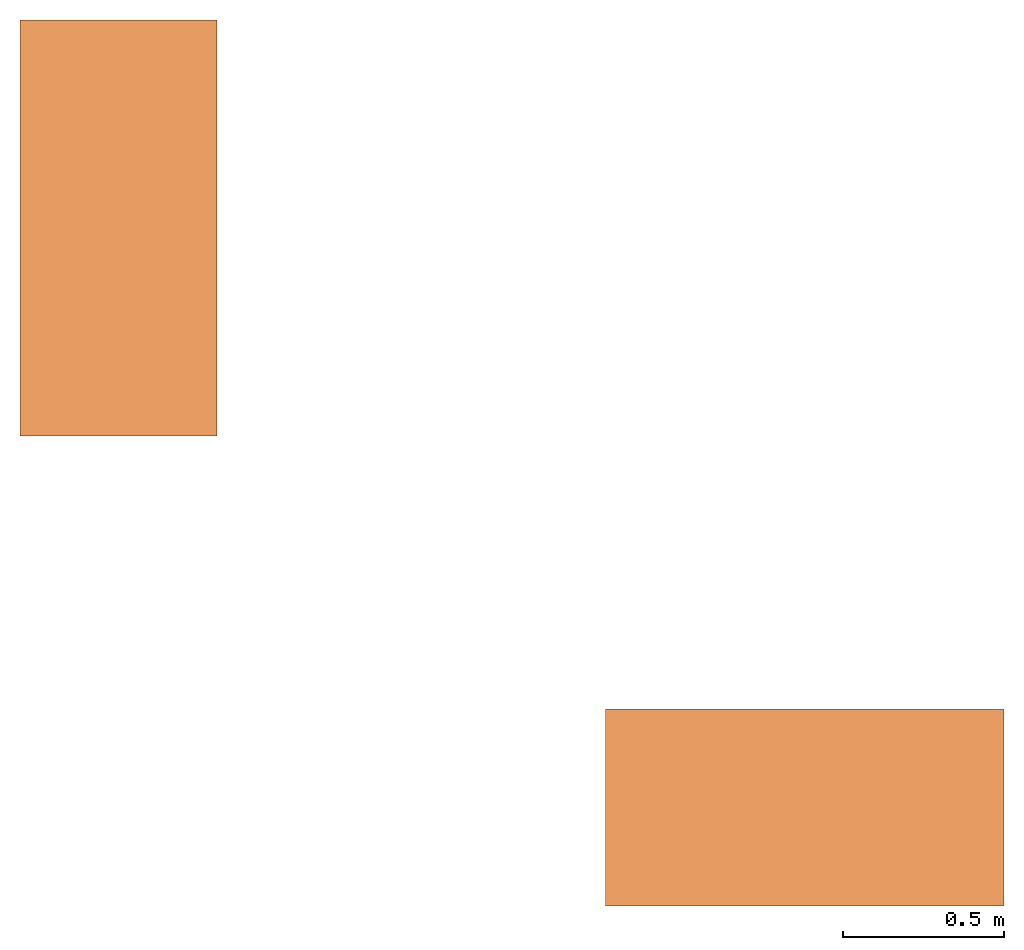
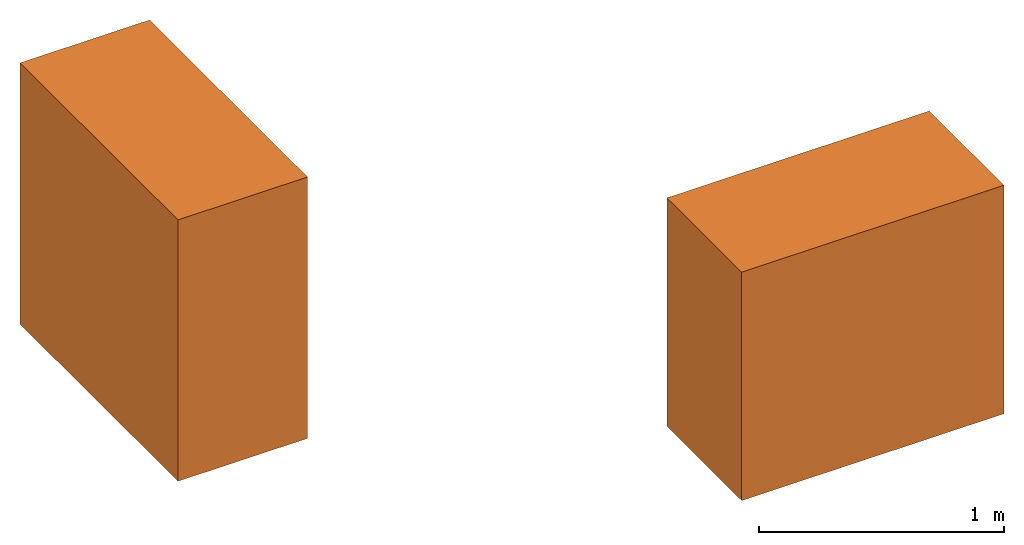
# One storey: 2 virtual elements.
"""IFC4 building model written with IfcOpenShell, lengths in feet."""

import ifcopenshell
import ifcopenshell.guid

model = None  # the IFC model being written
_history = None  # IfcOwnerHistory: only IFC2X3 demands one
_inside = {}  # id of a spatial element -> (the spatial element, [elements in it])
_under = {}  # id of a project, library or spatial element -> (it, [spatial elements below it])
_declared = {}  # id of a project -> (the project, [libraries it declares])
_typed = {}  # id of a type object -> (the type object, [elements of that type])
_made_of = {}  # id of a material, layer set ... -> (it, [elements and type objects made of it])


def new_model(schema):
    """Start an empty IFC model of exactly this schema.

    Asked for "IFC4X3", IfcOpenShell would pick the latest addendum, in which some entities
    have other attributes; the version numbers below select the first issue.
    IFC2X3 requires an IfcOwnerHistory on every rooted entity: one is made here for all.
    """
    global model, _history
    if schema == "IFC4X3":
        model = ifcopenshell.file(schema_version=(4, 3, 0, 0))
    else:
        model = ifcopenshell.file(schema=schema)
    _inside.clear()
    _under.clear()
    _declared.clear()
    _typed.clear()
    _made_of.clear()
    _history = None
    if model.schema == "IFC2X3":
        org = make("IfcOrganization", Name="unknown")
        user = make(
            "IfcPersonAndOrganization",
            ThePerson=make("IfcPerson", FamilyName="unknown"),
            TheOrganization=org,
        )
        app = make(
            "IfcApplication",
            ApplicationDeveloper=org,
            Version="unknown",
            ApplicationFullName="unknown",
            ApplicationIdentifier="unknown",
        )
        _history = make(
            "IfcOwnerHistory",
            OwningUser=user,
            OwningApplication=app,
            ChangeAction="ADDED",
            CreationDate=0,
        )
    return model


def make(cls, **values):
    """One entity of the class cls with the attributes given. An attribute that is None is left unset."""
    return model.create_entity(
        cls, **{name: value for name, value in values.items() if value is not None}
    )


def entity(cls, *values):
    """Any entity or typed value of the class cls, its attributes in the order of the schema. None: left unset."""
    e = model.create_entity(cls)
    for i, value in enumerate(values):
        if value is not None:
            e[i] = value
    return e


def rooted(cls, **values):
    """An entity with a GlobalId (a new one), such as an element, a storey or a relation."""
    return make(cls, GlobalId=ifcopenshell.guid.new(), OwnerHistory=_history, **values)


def si_unit(unit_type, name, prefix=None):
    """IfcSIUnit, for example si_unit("LENGTHUNIT", "METRE", prefix="MILLI")."""
    return make("IfcSIUnit", UnitType=unit_type, Prefix=prefix, Name=name)


def converted_unit(unit_type, name, factor, base, dimensions=None, offset=None):
    """IfcConversionBasedUnit, such as the inch: factor (a typed value) times the base unit."""
    return make(
        "IfcConversionBasedUnit"
        if offset is None
        else "IfcConversionBasedUnitWithOffset",
        ConversionOffset=offset,
        Dimensions=None
        if dimensions is None
        else entity("IfcDimensionalExponents", *dimensions),
        UnitType=unit_type,
        Name=name,
        ConversionFactor=make(
            "IfcMeasureWithUnit", ValueComponent=factor, UnitComponent=base
        ),
    )


def assignment(units):
    """IfcUnitAssignment: the units of a project."""
    return None if units is None else make("IfcUnitAssignment", Units=units)


def point(xyz):
    """IfcCartesianPoint."""
    return None if xyz is None else make("IfcCartesianPoint", Coordinates=xyz)


def direction(xyz):
    """IfcDirection."""
    return None if xyz is None else make("IfcDirection", DirectionRatios=xyz)


def frame(location, z_axis=None, x_axis=None):
    """IfcAxis2Placement3D, a coordinate frame: its origin and axes. An axis left out is left unset."""
    return make(
        "IfcAxis2Placement3D",
        Location=point(location),
        Axis=direction(z_axis),
        RefDirection=direction(x_axis),
    )


def frame_2d(location, x_axis=None):
    """IfcAxis2Placement2D, a coordinate frame in the plane: its origin and x axis."""
    return make(
        "IfcAxis2Placement2D", Location=point(location), RefDirection=direction(x_axis)
    )


def origin_with_axes():
    """The frame at (0, 0, 0) with the z axis (0, 0, 1) and the x axis (1, 0, 0) written out."""
    return frame((0.0, 0.0, 0.0), z_axis=(0.0, 0.0, 1.0), x_axis=(1.0, 0.0, 0.0))


def origin_2d_with_axis():
    """The frame at (0, 0) in the plane with the x axis (1, 0) written out."""
    return frame_2d((0.0, 0.0), x_axis=(1.0, 0.0))


def place(relative_to, where):
    """IfcLocalPlacement: puts the frame where relative to a parent placement (None: the world)."""
    return make(
        "IfcLocalPlacement", PlacementRelTo=relative_to, RelativePlacement=where
    )


def context(
    kind, dimensions, precision=None, world=None, true_north=None, identifier=None
):
    """IfcGeometricRepresentationContext, for example the 3D "Model" context."""
    return make(
        "IfcGeometricRepresentationContext",
        ContextIdentifier=identifier,
        ContextType=kind,
        CoordinateSpaceDimension=dimensions,
        Precision=precision,
        WorldCoordinateSystem=world,
        TrueNorth=true_north,
    )


def subcontext(parent, identifier, kind, view, scale=None):
    """IfcGeometricRepresentationSubContext, for example "Body" below "Model"."""
    return make(
        "IfcGeometricRepresentationSubContext",
        ContextIdentifier=identifier,
        ContextType=kind,
        ParentContext=parent,
        TargetScale=scale,
        TargetView=view,
    )


def project(units=None, contexts=None):
    """IfcProject with its units and contexts."""
    return rooted(
        "IfcProject",
        Name="project",
        RepresentationContexts=contexts,
        UnitsInContext=assignment(units),
    )


def spatial(cls, under=None, at=None, **own):
    """A site, building, storey or space (cls), placed at a placement, below another one or the project."""
    s = rooted(cls, ObjectPlacement=at, **own)
    if under is not None:
        _under.setdefault(under.id(), (under, []))[1].append(s)
    return s


def point_list(points):
    """IfcCartesianPointList2D or 3D."""
    cls = (
        "IfcCartesianPointList2D" if len(points[0]) == 2 else "IfcCartesianPointList3D"
    )
    return make(cls, CoordList=points)


def polygons(points, faces, closed=None, point_numbers=None):
    """IfcPolygonalFaceSet: a face is its outer loop, then its inner loops; points numbered from 1."""
    made = []
    for loops in faces:
        if len(loops) == 1:
            made.append(make("IfcIndexedPolygonalFace", CoordIndex=loops[0]))
        else:
            made.append(
                make(
                    "IfcIndexedPolygonalFaceWithVoids",
                    CoordIndex=loops[0],
                    InnerCoordIndices=loops[1:],
                )
            )
    return make(
        "IfcPolygonalFaceSet",
        Coordinates=point_list(points),
        Closed=closed,
        Faces=made,
        PnIndex=point_numbers,
    )


def shape(context_of_items, identifier, shape_type, items):
    """IfcShapeRepresentation: the items that make up one representation, for example the "Body"."""
    return make(
        "IfcShapeRepresentation",
        ContextOfItems=context_of_items,
        RepresentationIdentifier=identifier,
        RepresentationType=shape_type,
        Items=items,
    )


def made_of(thing, what):
    """Note that an element or type object is made of a material, layer set ...; save() writes the relation."""
    if what is not None:
        _made_of.setdefault(what.id(), (what, []))[1].append(thing)
    return thing


def element(
    cls,
    number,
    at=None,
    inside=None,
    cuts=None,
    type_object=None,
    material=None,
    context=None,
    identifier="Body",
    shape_type=None,
    held_by="IfcProductDefinitionShape",
    body=None,
    shapes=None,
    **own,
):
    """One element of the class cls, such as IfcWall. Its Tag is "e" and its number.

    at: its placement. inside: the storey or other place that contains it. cuts: it is an
    opening in that element (IfcRelVoidsElement). A single representation is given by context,
    identifier, shape_type and body (its items); several are given by shapes. held_by: the class
    of the entity that holds the representations. save() writes the other relations.
    """
    e = rooted(cls, Tag="e%d" % number, ObjectPlacement=at, **own)
    if body is not None:
        shapes = [shape(context, identifier, shape_type, body)]
    if shapes is not None:
        e.Representation = make(held_by, Representations=shapes)
    if inside is not None:
        _inside.setdefault(inside.id(), (inside, []))[1].append(e)
    if cuts is not None:
        rooted(
            "IfcRelVoidsElement", RelatingBuildingElement=cuts, RelatedOpeningElement=e
        )
    if type_object is not None:
        _typed.setdefault(type_object.id(), (type_object, []))[1].append(e)
    return made_of(e, material)


def aggregate(whole, parts):
    """IfcRelAggregates: a whole, such as a stair, and the parts it consists of."""
    return rooted("IfcRelAggregates", RelatingObject=whole, RelatedObjects=parts)


def save(model, path):
    """Write the relations noted so far, then the file.

    IfcRelAggregates (storeys below a building ...), IfcRelContainedInSpatialStructure (elements
    in a storey), IfcRelDefinesByType, IfcRelAssociatesMaterial and IfcRelDeclares: one each for
    every whole, place, type object, material and project.
    """
    for whole, parts in _under.values():
        aggregate(whole, parts)
    for where, things in _inside.values():
        rooted(
            "IfcRelContainedInSpatialStructure",
            RelatedElements=things,
            RelatingStructure=where,
        )
    for kind, things in _typed.values():
        rooted("IfcRelDefinesByType", RelatedObjects=things, RelatingType=kind)
    for what, things in _made_of.values():
        rooted("IfcRelAssociatesMaterial", RelatedObjects=things, RelatingMaterial=what)
    for by, libraries in _declared.values():
        rooted("IfcRelDeclares", RelatingContext=by, RelatedDefinitions=libraries)
    model.write(path)


model = new_model("IFC4")

# Units and contexts
model_context = context("Model", 3, precision=1e-05, world=origin_with_axes())
plan_context = context("Plan", 2, precision=1e-05, world=origin_2d_with_axis())
body_context = subcontext(model_context, "Body", "Model", "MODEL_VIEW")
ifc_project = project(units=[converted_unit("AREAUNIT", "square foot", entity("IfcReal", 0.09290304), si_unit("AREAUNIT", "SQUARE_METRE"), dimensions=[2, 0, 0, 0, 0, 0, 0]), converted_unit("LENGTHUNIT", "foot", entity("IfcReal", 0.3048), si_unit("LENGTHUNIT", "METRE"), dimensions=[1, 0, 0, 0, 0, 0, 0]), converted_unit("VOLUMEUNIT", "cubic foot", entity("IfcReal", 0.0283168467116885), si_unit("VOLUMEUNIT", "CUBIC_METRE"), dimensions=[3, 0, 0, 0, 0, 0, 0]), converted_unit("PLANEANGLEUNIT", "degree", entity("IfcReal", 0.0174532925199433), si_unit("PLANEANGLEUNIT", "RADIAN"), dimensions=[0, 0, 0, 0, 0, 0, 0])], contexts=[model_context, plan_context])

# Site, building, storey
site_placement = place(None, origin_with_axes())
site = spatial("IfcSite", under=ifc_project, at=site_placement)
building_placement = place(site_placement, origin_with_axes())
building = spatial("IfcBuilding", under=site, at=building_placement, Name="Building")
storey_placement = place(building_placement, origin_with_axes())
storey = spatial("IfcBuildingStorey", under=building, at=storey_placement, Name="Storey")

# Virtual elements
virtual_element_1_placement = place(storey_placement, frame((-19.0630390888124, 9.66825040932402, 5.72635941305186), z_axis=(0.0, -0.999999999999999, -4.37113882867379e-08), x_axis=(1.0, 0.0, 0.0)))
element("IfcVirtualElement", 1, at=virtual_element_1_placement, inside=storey, Name="Plane", context=body_context, shape_type="Tessellation", body=[
    polygons([(-1.0, -3.26580762863159, 9.90415927049071e-08), (1.0, -3.26580762863159, 9.90415927049071e-08), (-1.0, 1.0, 0.0), (1.0, 1.0, 0.0), (-1.0, -3.26580762863159, 4.22661685943604), (1.0, -3.26580762863159, 4.22661685943604), (-1.0, 1.00000023841858, 4.22661685943604), (1.0, 1.00000023841858, 4.22661685943604)], [[[1, 3, 4, 2]], [[5, 6, 8, 7]], [[2, 4, 8, 6]], [[3, 1, 5, 7]], [[4, 3, 7, 8]], [[1, 2, 6, 5]]], closed=True),
])
virtual_element_2_placement = place(storey_placement, frame((-10.0666456648058, 1.66868365655734, 5.68605939860106), z_axis=(0.999999999999997, 0.0, 7.54979012640431e-08), x_axis=(7.54979012640431e-08, 0.0, -0.999999999999997)))
element("IfcVirtualElement", 2, at=virtual_element_2_placement, inside=storey, Name="Plane", context=body_context, shape_type="Tessellation", body=[
    polygons([(-1.0, -1.0, 0.0), (2.72890758514404, -1.0, -1.30528889030757e-07), (-1.0, 1.0, 0.0), (2.72890758514404, 1.0, -1.30528889030757e-07), (-1.00000035762787, -1.0, -4.05070924758911), (2.72890710830688, -1.0, -4.05070924758911), (-1.00000035762787, 1.0, -4.05070924758911), (2.72890710830688, 1.0, -4.05070924758911)], [[[1, 3, 4, 2]], [[5, 6, 8, 7]], [[1, 2, 6, 5]], [[2, 4, 8, 6]], [[3, 1, 5, 7]], [[4, 3, 7, 8]]], closed=True),
])

save(model, "model.ifc")
